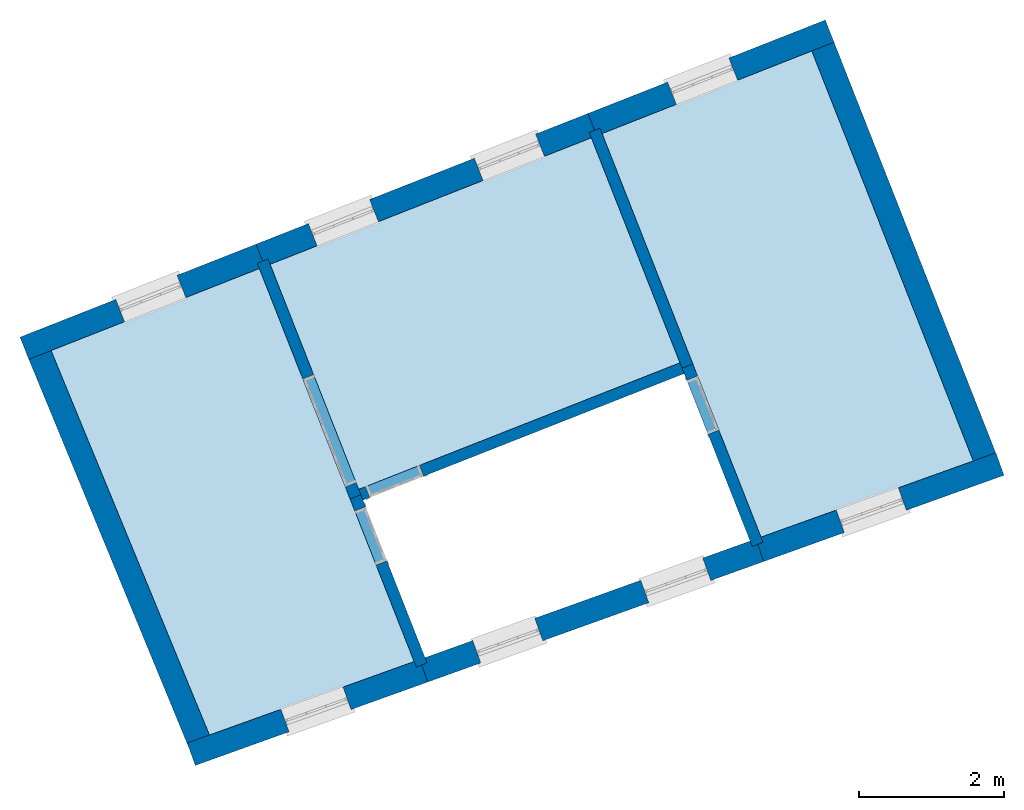
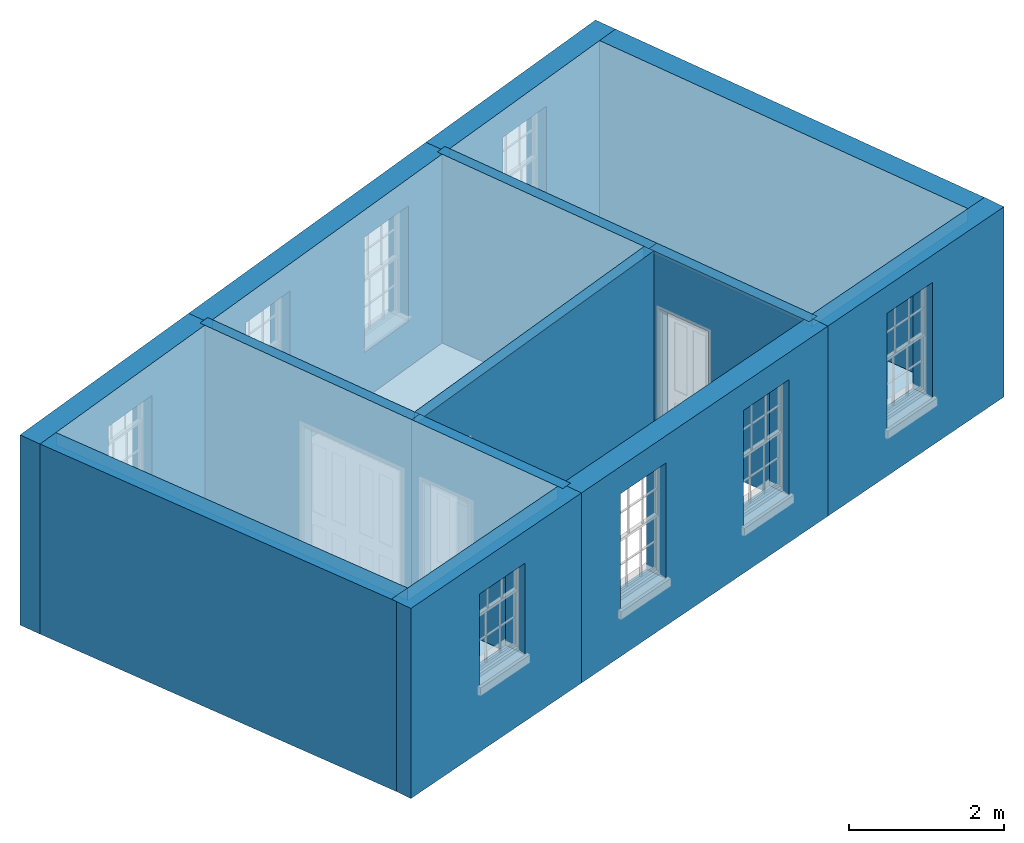
# One storey, part 1 of 6: 13 walls, 6 slabs, 12 openings.
"""IFC2X3 building model written with IfcOpenShell, lengths in metres."""

from ifc_helpers import new_model, si_unit, frame, origin, place, context, subcontext, project, spatial, polyline, outline, extrude, material, layer, layer_set, layer_usage, element, save


model = new_model("IFC2X3")

# Units and contexts
model_context = context("Model", 3, world=origin())
body_context = subcontext(model_context, "Body", "Model", "MODEL_VIEW")
ifc_project = project(units=[si_unit("PLANEANGLEUNIT", "RADIAN"), si_unit("MASSUNIT", "GRAM", prefix="KILO"), si_unit("FORCEUNIT", "NEWTON", prefix="KILO"), si_unit("LENGTHUNIT", "METRE")], contexts=[model_context])

# Site, building, storey
site_placement = place(None, origin())
site = spatial("IfcSite", under=ifc_project, at=site_placement, CompositionType="ELEMENT")
building_placement = place(None, origin())
building = spatial("IfcBuilding", under=site, at=building_placement, Name="Building plot-4", CompositionType="ELEMENT")
storey_placement = place(None, frame((0.0, 0.0, 6.45)))
storey = spatial("IfcBuildingStorey", under=building, at=storey_placement, Name="Floor 1", CompositionType="ELEMENT", Elevation=6.45)

# Slabs
slab_1_placement = place(storey_placement, frame((0.0, 0.0, 2.8)))
element("IfcSlab", 1, at=slab_1_placement, inside=storey, Name="Slab", ObjectType="Slab", PredefinedType="FLOOR", context=body_context, shape_type="SweptSolid", body=[
    extrude(outline(polyline([(48.7503993592312, 48.8902730912423), (53.185811513538, 50.6370275000616), (51.9622563685918, 53.743916100977), (47.5268442142849, 51.9971616921577), (48.7503993592312, 48.8902730912423)])), origin(), (0.0, 0.0, 1.0), 0.2),
])
slab_2_placement = place(storey_placement, frame((0.0, 0.0, 2.8)))
element("IfcSlab", 2, at=slab_2_placement, inside=storey, Name="Slab", ObjectType="Slab", PredefinedType="FLOOR", context=body_context, shape_type="SweptSolid", body=[
    extrude(outline(polyline([(52.1111277674981, 53.8025446485257), (54.3055353434882, 48.2304378973377), (57.2362120204166, 49.2819023334951), (55.0067914405798, 54.9429151736193), (52.1111277674981, 53.8025446485257)])), origin(), (0.0, 0.0, 1.0), 0.2),
])
slab_3_placement = place(storey_placement, frame((0.0, 0.0, 2.8)))
element("IfcSlab", 3, at=slab_3_placement, inside=storey, Name="Slab", ObjectType="Slab", PredefinedType="FLOOR", context=body_context, shape_type="SweptSolid", body=[
    extrude(outline(polyline([(47.3779728153786, 51.938533144609), (44.502052775966, 50.8059380590818), (46.6888976082681, 45.4977503358858), (49.5151493068038, 46.5117493116291), (47.3779728153786, 51.938533144609)])), origin(), (0.0, 0.0, 1.0), 0.2),
])
slab_4_placement = place(storey_placement, origin())
element("IfcSlab", 4, at=slab_4_placement, inside=storey, Name="Slab", ObjectType="Slab", PredefinedType="FLOOR", context=body_context, shape_type="SweptSolid", body=[
    extrude(outline(polyline([(48.7503993592312, 48.8902730912423), (53.185811513538, 50.6370275000616), (51.9622563685918, 53.743916100977), (47.5268442142849, 51.9971616921577), (48.7503993592312, 48.8902730912423)])), origin(), (0.0, 0.0, 1.0), 0.02),
])
slab_5_placement = place(storey_placement, origin())
element("IfcSlab", 5, at=slab_5_placement, inside=storey, Name="Slab", ObjectType="Slab", PredefinedType="FLOOR", context=body_context, shape_type="SweptSolid", body=[
    extrude(outline(polyline([(52.1111277674981, 53.8025446485257), (54.3055353434882, 48.2304378973377), (57.2362120204166, 49.2819023334951), (55.0067914405798, 54.9429151736193), (52.1111277674981, 53.8025446485257)])), origin(), (0.0, 0.0, 1.0), 0.02),
])
slab_6_placement = place(storey_placement, origin())
element("IfcSlab", 6, at=slab_6_placement, inside=storey, Name="Slab", ObjectType="Slab", PredefinedType="FLOOR", context=body_context, shape_type="SweptSolid", body=[
    extrude(outline(polyline([(47.3779728153786, 51.938533144609), (44.502052775966, 50.8059380590818), (46.6888976082681, 45.4977503358858), (49.5151493068038, 46.5117493116291), (47.3779728153786, 51.938533144609)])), origin(), (0.0, 0.0, 1.0), 0.02),
])

# Wall, opening
ifc_material_1 = material(Name="Masonry")
ifc_layer_1 = layer(ifc_material_1, 0.33, ventilated=False)
ifc_layer_set_1 = layer_set([ifc_layer_1], Name="My Wall")
ifc_layer_usage_1 = layer_usage(ifc_layer_set_1, "AXIS2", "NEGATIVE", 0.08)
wall_1_placement = place(storey_placement, origin())
wall_1 = element("IfcWallStandardCase", 7, at=wall_1_placement, inside=storey, material=ifc_layer_usage_1, Name="exterior", context=body_context, shape_type="SweptSolid", body=[
    extrude(outline(polyline([(55.3138387008242, 55.0638365529384), (55.192917321505, 55.3708838131828), (51.9157706887258, 54.0802776349957), (52.0366920680449, 53.7732303747513), (55.3138387008242, 55.0638365529384)])), origin(), (0.0, 0.0, 1.0), 3.0),
])
opening_1_placement = place(storey_placement, frame((0.0, 0.0, 0.75)))
element("IfcOpeningElement", 8, at=opening_1_placement, cuts=wall_1, Name="Opening", ObjectType="Opening", context=body_context, shape_type="SweptSolid", body=[
    extrude(outline(polyline([(53.8613912653598, 54.8465021034084), (53.0146851840799, 54.5130522392253), (53.1356065633991, 54.2060049789809), (53.9823126446789, 54.539454843164), (53.8613912653598, 54.8465021034084)])), origin(), (0.0, 0.0, 1.0), 1.82),
])

# Wall, openings
wall_2_placement = place(storey_placement, origin())
wall_2 = element("IfcWallStandardCase", 9, at=wall_2_placement, inside=storey, material=ifc_layer_usage_1, Name="exterior", context=body_context, shape_type="SweptSolid", body=[
    extrude(outline(polyline([(52.0366920680449, 53.7732303747513), (51.9157706887258, 54.0802776349957), (47.3314871355126, 52.2748946786277), (47.4524085148317, 51.9678474183833), (52.0366920680449, 53.7732303747513)])), origin(), (0.0, 0.0, 1.0), 3.0),
])
opening_2_placement = place(storey_placement, frame((0.0, 0.0, 0.75)))
element("IfcOpeningElement", 10, at=opening_2_placement, cuts=wall_2, Name="Opening", ObjectType="Opening", context=body_context, shape_type="SweptSolid", body=[
    extrude(outline(polyline([(51.1930528410624, 53.7956568279952), (50.3463467597826, 53.4622069638121), (50.4672681391017, 53.1551597035678), (51.3139742203816, 53.4886095677509), (51.1930528410624, 53.7956568279952)])), origin(), (0.0, 0.0, 1.0), 1.82),
])
opening_3_placement = place(storey_placement, frame((0.0, 0.0, 0.75)))
element("IfcOpeningElement", 11, at=opening_3_placement, cuts=wall_2, Name="Opening", ObjectType="Opening", context=body_context, shape_type="SweptSolid", body=[
    extrude(outline(polyline([(48.9009110644558, 52.8929653498112), (48.054204983176, 52.5595154856281), (48.1751263624951, 52.2524682253838), (49.021832443775, 52.5859180895669), (48.9009110644558, 52.8929653498112)])), origin(), (0.0, 0.0, 1.0), 1.82),
])

# Wall, opening
wall_3_placement = place(storey_placement, origin())
wall_3 = element("IfcWallStandardCase", 12, at=wall_3_placement, inside=storey, material=ifc_layer_usage_1, Name="exterior", context=body_context, shape_type="SweptSolid", body=[
    extrude(outline(polyline([(47.4524085148317, 51.9678474183833), (47.3314871355126, 52.2748946786277), (44.0729122767796, 50.9916024381462), (44.1938336560988, 50.6845551779018), (47.4524085148317, 51.9678474183833)])), origin(), (0.0, 0.0, 1.0), 3.0),
])
opening_4_placement = place(storey_placement, frame((0.0, 0.0, 1.05)))
element("IfcOpeningElement", 13, at=opening_4_placement, cuts=wall_3, Name="Opening", ObjectType="Opening", context=body_context, shape_type="SweptSolid", body=[
    extrude(outline(polyline([(46.2418585271816, 51.8457770432509), (45.3951524459018, 51.5123271790678), (45.5160738252209, 51.2052799188234), (46.3627799065008, 51.5387297830065), (46.2418585271816, 51.8457770432509)])), origin(), (0.0, 0.0, 1.0), 1.445),
])

wall_4_placement = place(storey_placement, origin())
wall_4 = element("IfcWallStandardCase", 14, at=wall_4_placement, inside=storey, material=ifc_layer_usage_1, Name="exterior", context=body_context, shape_type="SweptSolid", body=[
    extrude(outline(polyline([(46.3816931332496, 45.3875319065881), (46.4931346698559, 45.0769183461649), (49.70423854185, 46.2289940933087), (49.5927970052436, 46.539607653732), (46.3816931332496, 45.3875319065881)])), origin(), (0.0, 0.0, 1.0), 3.0),
])
opening_5_placement = place(storey_placement, frame((0.0, 0.0, 1.05)))
element("IfcOpeningElement", 15, at=opening_5_placement, cuts=wall_4, Name="Opening", ObjectType="Opening", context=body_context, shape_type="SweptSolid", body=[
    extrude(outline(polyline([(47.7880730454297, 45.5415146831305), (48.6446134696272, 45.8488231628631), (48.5331719330208, 46.1594367232864), (47.6766315088233, 45.8521282435537), (47.7880730454297, 45.5415146831305)])), origin(), (0.0, 0.0, 1.0), 1.445),
])

# Wall, openings
wall_5_placement = place(storey_placement, origin())
wall_5 = element("IfcWallStandardCase", 16, at=wall_5_placement, inside=storey, material=ifc_layer_usage_1, Name="exterior", context=body_context, shape_type="SweptSolid", body=[
    extrude(outline(polyline([(49.5927970052436, 46.539607653732), (49.70423854185, 46.2289940933087), (54.3439530966588, 47.8936249571326), (54.2325115600524, 48.2042385175559), (49.5927970052436, 46.539607653732)])), origin(), (0.0, 0.0, 1.0), 3.0),
])
opening_6_placement = place(storey_placement, frame((0.0, 0.0, 0.75)))
element("IfcOpeningElement", 17, at=opening_6_placement, cuts=wall_5, Name="Opening", ObjectType="Opening", context=body_context, shape_type="SweptSolid", body=[
    extrude(outline(polyline([(50.4358969684534, 46.4914975693984), (51.2924373926509, 46.7988060491311), (51.1809958560445, 47.1094196095543), (50.3244554318471, 46.8021111298216), (50.4358969684534, 46.4914975693984)])), origin(), (0.0, 0.0, 1.0), 1.82),
])
opening_7_placement = place(storey_placement, frame((0.0, 0.0, 0.75)))
element("IfcOpeningElement", 18, at=opening_7_placement, cuts=wall_5, Name="Opening", ObjectType="Opening", context=body_context, shape_type="SweptSolid", body=[
    extrude(outline(polyline([(52.7557542458578, 47.3238130013103), (53.6122946700553, 47.631121481043), (53.5008531334489, 47.9417350414663), (52.6443127092515, 47.6344265617336), (52.7557542458578, 47.3238130013103)])), origin(), (0.0, 0.0, 1.0), 1.82),
])

# Wall, opening
wall_6_placement = place(storey_placement, origin())
wall_6 = element("IfcWallStandardCase", 19, at=wall_6_placement, inside=storey, material=ifc_layer_usage_1, Name="exterior", context=body_context, shape_type="SweptSolid", body=[
    extrude(outline(polyline([(54.2325115600524, 48.2042385175559), (54.3439530966588, 47.8936249571326), (57.6606145588137, 49.0835725216947), (57.5491730222074, 49.394186082118), (54.2325115600524, 48.2042385175559)])), origin(), (0.0, 0.0, 1.0), 3.0),
])
opening_8_placement = place(storey_placement, frame((0.0, 0.0, 0.75)))
element("IfcOpeningElement", 20, at=opening_8_placement, cuts=wall_6, Name="Opening", ObjectType="Opening", context=body_context, shape_type="SweptSolid", body=[
    extrude(outline(polyline([(55.456356963962, 48.2927317962874), (56.3128973881595, 48.60004027602), (56.2014558515532, 48.9106538364433), (55.3449154273557, 48.6033453567106), (55.456356963962, 48.2927317962874)])), origin(), (0.0, 0.0, 1.0), 1.82),
])

# Walls
wall_7_placement = place(storey_placement, origin())
element("IfcWallStandardCase", 21, at=wall_7_placement, inside=storey, material=ifc_layer_usage_1, Name="party", context=body_context, shape_type="SweptSolid", body=[
    extrude(outline(polyline([(57.2664401494896, 49.2051461447514), (57.573487409734, 49.3260675240705), (55.2845244270499, 55.1382722523916), (54.9774771668055, 55.0173508730725), (57.2664401494896, 49.2051461447514)])), origin(), (0.0, 0.0, 1.0), 3.0),
])
wall_8_placement = place(storey_placement, origin())
element("IfcWallStandardCase", 22, at=wall_8_placement, inside=storey, material=ifc_layer_usage_1, Name="party", context=body_context, shape_type="SweptSolid", body=[
    extrude(outline(polyline([(44.4710996926754, 50.8810713169569), (44.1659786007411, 50.7553688139714), (46.4128702243124, 45.3014278871074), (46.7179913162467, 45.4271303900929), (44.4710996926754, 50.8810713169569)])), origin(), (0.0, 0.0, 1.0), 3.0),
])

# Wall, opening
ifc_material_2 = material(Name="Masonry")
ifc_layer_2 = layer(ifc_material_2, 0.16, ventilated=False)
ifc_layer_set_2 = layer_set([ifc_layer_2], Name="My Wall")
ifc_layer_usage_2 = layer_usage(ifc_layer_set_2, "AXIS2", "NEGATIVE", 0.08)
wall_9_placement = place(storey_placement, origin())
wall_9 = element("IfcWallStandardCase", 23, at=wall_9_placement, inside=storey, material=ifc_layer_usage_2, Name="interior", context=body_context, shape_type="SweptSolid", body=[
    extrude(outline(polyline([(53.3188757605398, 50.5174703749296), (53.2602472129912, 50.666341773836), (48.675963659778, 48.860958817468), (48.7345922073266, 48.7120874185616), (53.3188757605398, 50.5174703749296)])), origin(), (0.0, 0.0, 1.0), 3.0),
])
opening_9_placement = place(storey_placement, frame((0.0, 0.0, 0.0199999999999996)))
element("IfcOpeningElement", 24, at=opening_9_placement, cuts=wall_9, Name="Opening", ObjectType="Opening", context=body_context, shape_type="SweptSolid", body=[
    extrude(outline(polyline([(49.5878009780793, 49.2200586712036), (48.8434439835476, 48.9269159334602), (48.9020725310963, 48.7780445345539), (49.646429525628, 49.0711872722973), (49.5878009780793, 49.2200586712036)])), origin(), (0.0, 0.0, 1.0), 2.1),
])

wall_10_placement = place(storey_placement, origin())
wall_10 = element("IfcWallStandardCase", 25, at=wall_10_placement, inside=storey, material=ifc_layer_usage_2, Name="interior", context=body_context, shape_type="SweptSolid", body=[
    extrude(outline(polyline([(53.3639971862187, 50.6212203481571), (53.2151257873123, 50.5625918006085), (54.1850919906856, 48.0996239867093), (54.333963389592, 48.1582525342579), (53.3639971862187, 50.6212203481571)])), origin(), (0.0, 0.0, 1.0), 3.0),
])
opening_10_placement = place(storey_placement, frame((0.0, 0.0, 0.0199999999999996)))
element("IfcOpeningElement", 26, at=opening_10_placement, cuts=wall_10, Name="Opening", ObjectType="Opening", context=body_context, shape_type="SweptSolid", body=[
    extrude(outline(polyline([(53.2810829033046, 50.3951114768388), (53.574225641048, 49.6507544823071), (53.7230970399543, 49.7093830298558), (53.4299543022109, 50.4537400243875), (53.2810829033046, 50.3951114768388)])), origin(), (0.0, 0.0, 1.0), 2.1),
])

wall_11_placement = place(storey_placement, origin())
wall_11 = element("IfcWallStandardCase", 27, at=wall_11_placement, inside=storey, material=ifc_layer_usage_2, Name="interior", context=body_context, shape_type="SweptSolid", body=[
    extrude(outline(polyline([(48.7797136330055, 48.8158373917891), (48.6308422340991, 48.7572088442405), (49.5453774358768, 46.4349931228854), (49.6942488347832, 46.493621670434), (48.7797136330055, 48.8158373917891)])), origin(), (0.0, 0.0, 1.0), 3.0),
])
opening_11_placement = place(storey_placement, frame((0.0, 0.0, 0.0199999999999996)))
element("IfcOpeningElement", 28, at=opening_11_placement, cuts=wall_11, Name="Opening", ObjectType="Opening", context=body_context, shape_type="SweptSolid", body=[
    extrude(outline(polyline([(48.6967993500914, 48.5897285204708), (48.9899420878348, 47.8453715259391), (49.1388134867411, 47.9040000734878), (48.8456707489977, 48.6483570680195), (48.6967993500914, 48.5897285204708)])), origin(), (0.0, 0.0, 1.0), 2.1),
])

wall_12_placement = place(storey_placement, origin())
wall_12 = element("IfcWallStandardCase", 29, at=wall_12_placement, inside=storey, material=ifc_layer_usage_2, Name="interior", context=body_context, shape_type="SweptSolid", body=[
    extrude(outline(polyline([(48.6308422340991, 48.7572088442405), (48.7797136330055, 48.8158373917891), (47.4975299405106, 52.0715973916108), (47.3486585416042, 52.0129688440622), (48.6308422340991, 48.7572088442405)])), origin(), (0.0, 0.0, 1.0), 3.0),
])
opening_12_placement = place(storey_placement, frame((0.0, 0.0, 0.0199999999999996)))
element("IfcOpeningElement", 30, at=opening_12_placement, cuts=wall_12, Name="Opening", ObjectType="Opening", context=body_context, shape_type="SweptSolid", body=[
    extrude(outline(polyline([(48.7137565170132, 48.9833177155588), (48.1274710415265, 50.4720317046222), (47.9785996426201, 50.4134031570736), (48.5648851181069, 48.9246891680101), (48.7137565170132, 48.9833177155588)])), origin(), (0.0, 0.0, 1.0), 2.1),
])

# Wall
wall_13_placement = place(storey_placement, origin())
element("IfcWallStandardCase", 31, at=wall_13_placement, inside=storey, material=ifc_layer_usage_2, Name="interior", context=body_context, shape_type="SweptSolid", body=[
    extrude(outline(polyline([(53.2151257873123, 50.5625918006085), (53.3639971862187, 50.6212203481571), (52.0818134937238, 53.8769803479788), (51.9329420948174, 53.8183518004302), (53.2151257873123, 50.5625918006085)])), origin(), (0.0, 0.0, 1.0), 3.0),
])

save(model, "model.ifc")
